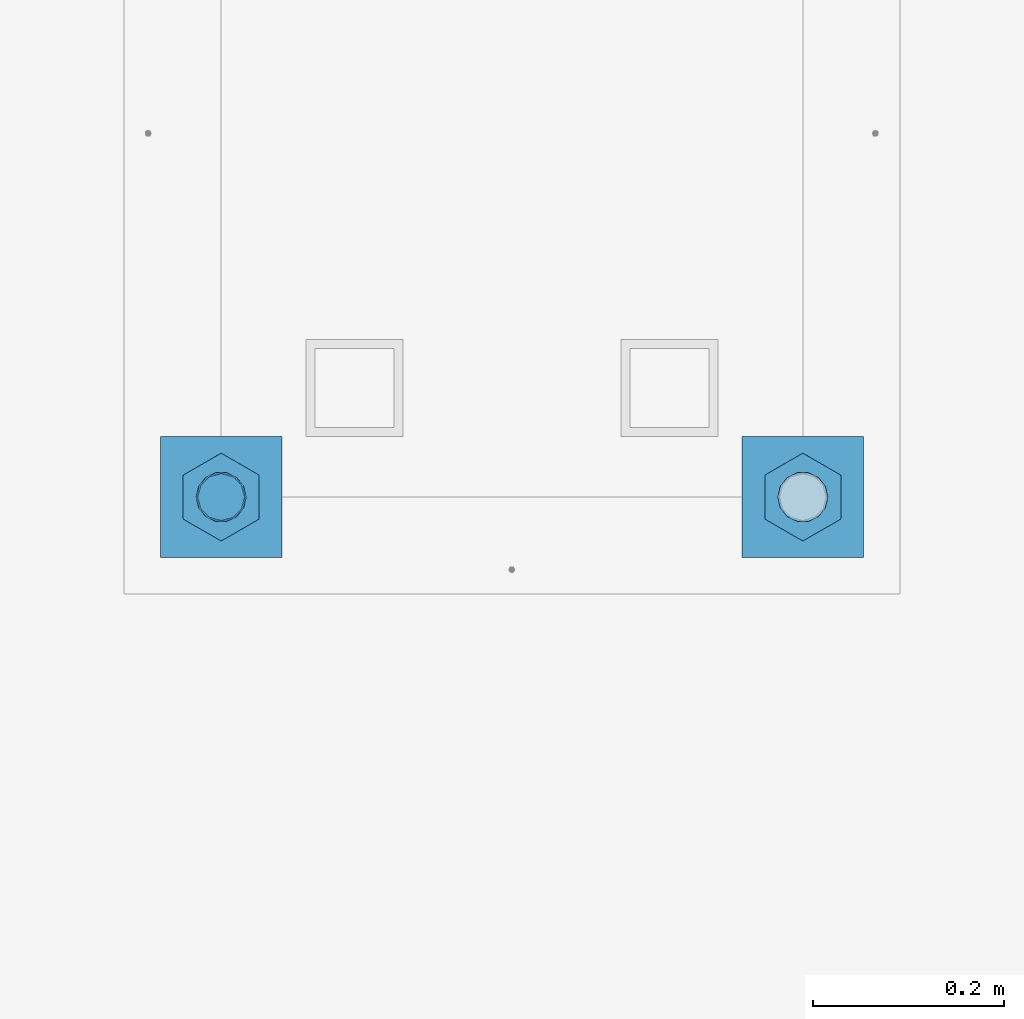
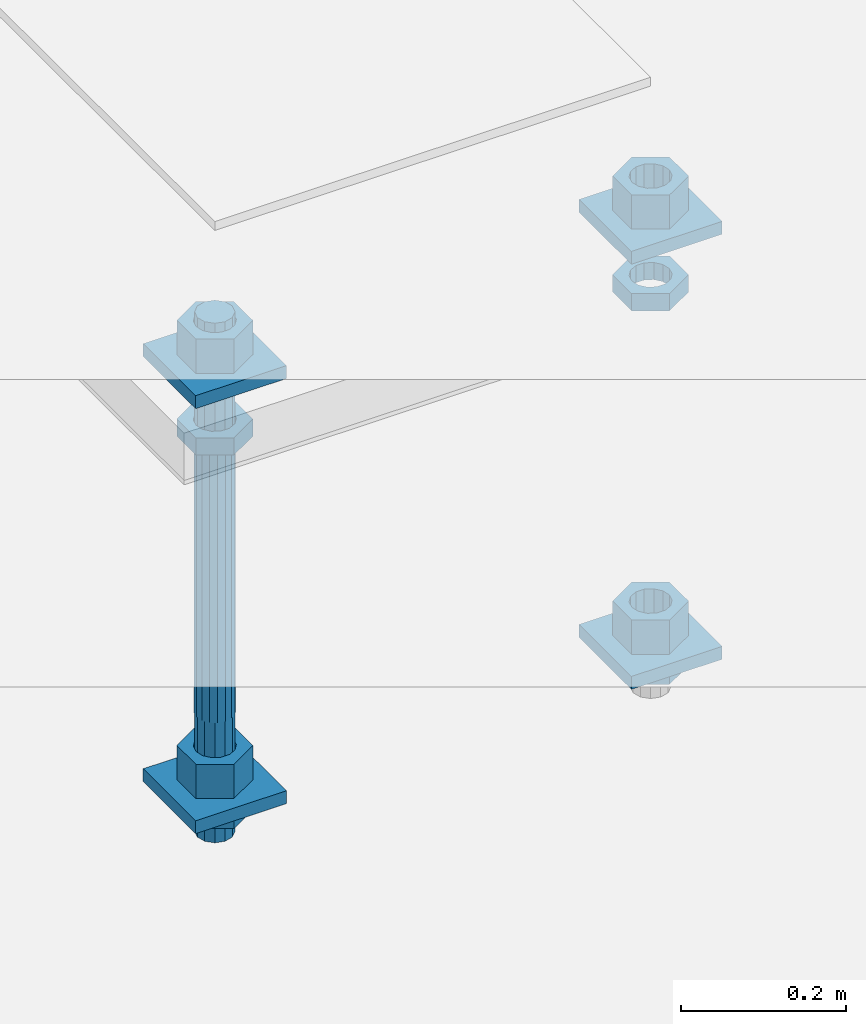
# One storey, part 2721 of 3843: 13 beams, 1 element without a shape of its own.
"""IFC2X3 building model written with IfcOpenShell, lengths in millimetres."""

from ifc_helpers import new_model, si_unit, frame, origin_with_axes, place, context, subcontext, project, spatial, faceted_brep, material, type_object, element, aggregate, save


model = new_model("IFC2X3")

# Units and contexts
model_context = context("Model", 3, precision=1e-05, world=origin_with_axes())
body_context = subcontext(model_context, "Body", "Model", "MODEL_VIEW")
ifc_project = project(units=[si_unit("LENGTHUNIT", "METRE", prefix="MILLI"), si_unit("AREAUNIT", "SQUARE_METRE"), si_unit("VOLUMEUNIT", "CUBIC_METRE"), si_unit("MASSUNIT", "GRAM", prefix="KILO"), si_unit("TIMEUNIT", "SECOND"), si_unit("PLANEANGLEUNIT", "RADIAN"), si_unit("SOLIDANGLEUNIT", "STERADIAN"), si_unit("THERMODYNAMICTEMPERATUREUNIT", "DEGREE_CELSIUS"), si_unit("LUMINOUSINTENSITYUNIT", "LUMEN")], contexts=[model_context])

# Site, building, storey
site_placement = place(None, origin_with_axes())
site = spatial("IfcSite", under=ifc_project, at=site_placement, CompositionType="ELEMENT")
building_placement = place(site_placement, origin_with_axes())
building = spatial("IfcBuilding", under=site, at=building_placement, Name="Undefined", CompositionType="ELEMENT")
storey_placement = place(building_placement, origin_with_axes())
storey = spatial("IfcBuildingStorey", under=building, at=storey_placement, Name="Undefined", CompositionType="ELEMENT", Elevation=0.0)

# Assembly, beams
assembly_placement = place(storey_placement, origin_with_axes())
assembly = element("IfcElementAssembly", 1, at=assembly_placement, inside=storey, Name="TEMPLATE", AssemblyPlace="NOTDEFINED", PredefinedType="RIGID_FRAME")
ifc_material_1 = material(Name="STEEL/A36")
beam_type_1 = type_object("IfcBeamType", PredefinedType="NOTDEFINED")
beam_1_placement = place(assembly_placement, frame((111798.099998474, 32080.2, 29873.575), z_axis=(0.0, 1.0, 0.0), x_axis=(-1.0, 0.0, 0.0)))
beam_1 = element("IfcBeam", 2, at=beam_1_placement, type_object=beam_type_1, material=ifc_material_1, Name="WASHER_PLATE", context=body_context, shape_type="Brep", body=[
    faceted_brep([(0.0, 9.52500000000146, -63.5), (0.0, 9.52500000000146, 63.5), (127.0, 9.52500000000146, 63.5), (127.0, 9.52500000000146, -63.5), (0.0, -9.52500000000146, 63.5), (127.0, -9.52500000000146, 63.5), (0.0, -9.52500000000146, -63.5), (127.0, -9.52500000000146, -63.5)], [[[0, 1, 2, 3]], [[1, 4, 5, 2]], [[4, 6, 7, 5]], [[6, 0, 3, 7]], [[5, 7, 3, 2]], [[6, 4, 1, 0]]]),
])
beam_2_placement = place(assembly_placement, frame((112407.7, 32080.2, 29873.575), z_axis=(0.0, 1.0, 0.0), x_axis=(-1.0, 0.0, 0.0)))
beam_2 = element("IfcBeam", 3, at=beam_2_placement, type_object=beam_type_1, material=ifc_material_1, Name="WASHER_PLATE", context=body_context, shape_type="Brep", body=[
    faceted_brep([(0.0, 9.52500000000146, -63.5), (0.0, 9.52500000000146, 63.5), (127.0, 9.52500000000146, 63.5), (127.0, 9.52500000000146, -63.5), (0.0, -9.52500000000146, 63.5), (127.0, -9.52500000000146, 63.5), (0.0, -9.52500000000146, -63.5), (127.0, -9.52500000000146, -63.5)], [[[0, 1, 2, 3]], [[1, 4, 5, 2]], [[4, 6, 7, 5]], [[6, 0, 3, 7]], [[5, 7, 3, 2]], [[6, 4, 1, 0]]]),
])
beam_3_placement = place(assembly_placement, frame((111798.099998474, 32080.2, 29244.925), z_axis=(0.0, 1.0, 0.0), x_axis=(-1.0, 0.0, 0.0)))
beam_3 = element("IfcBeam", 4, at=beam_3_placement, type_object=beam_type_1, material=ifc_material_1, Name="WASHER_PLATE", context=body_context, shape_type="Brep", body=[
    faceted_brep([(0.0, 9.52500000000146, -63.5), (0.0, 9.52500000000146, 63.5), (127.0, 9.52500000000146, 63.5), (127.0, 9.52500000000146, -63.5), (0.0, -9.52500000000146, 63.5), (127.0, -9.52500000000146, 63.5), (0.0, -9.52500000000146, -63.5), (127.0, -9.52500000000146, -63.5)], [[[0, 1, 2, 3]], [[1, 4, 5, 2]], [[4, 6, 7, 5]], [[6, 0, 3, 7]], [[5, 7, 3, 2]], [[6, 4, 1, 0]]]),
])
beam_4_placement = place(assembly_placement, frame((112407.7, 32080.2, 29244.925), z_axis=(0.0, 1.0, 0.0), x_axis=(-1.0, 0.0, 0.0)))
beam_4 = element("IfcBeam", 5, at=beam_4_placement, type_object=beam_type_1, material=ifc_material_1, Name="WASHER_PLATE", context=body_context, shape_type="Brep", body=[
    faceted_brep([(0.0, 9.52500000000146, -63.5), (0.0, 9.52500000000146, 63.5), (127.0, 9.52500000000146, 63.5), (127.0, 9.52500000000146, -63.5), (0.0, -9.52500000000146, 63.5), (127.0, -9.52500000000146, 63.5), (0.0, -9.52500000000146, -63.5), (127.0, -9.52500000000146, -63.5)], [[[0, 1, 2, 3]], [[1, 4, 5, 2]], [[4, 6, 7, 5]], [[6, 0, 3, 7]], [[5, 7, 3, 2]], [[6, 4, 1, 0]]]),
])
beam_type_2 = type_object("IfcBeamType", Name="2_HALF_NUT", PredefinedType="NOTDEFINED")
beam_5_placement = place(assembly_placement, frame((111734.599998474, 32080.2, 29787.85), z_axis=(-1.0, 0.0, 0.0), x_axis=(0.0, 0.0, -1.0)))
beam_5 = element("IfcBeam", 6, at=beam_5_placement, type_object=beam_type_2, material=ifc_material_1, Name="NUT", ObjectType="2_HALF_NUT", context=body_context, shape_type="Brep", body=[
    faceted_brep([(0.0, -46.0369987487793, 0.0), (0.0, -23.0184993743896, -39.869213104248), (25.4000000000015, -23.0184993743896, -39.869213104248), (25.4000000000015, -46.0369987487793, 0.0), (0.0, 23.0184993743896, -39.869213104248), (25.4000000000015, 23.0184993743896, -39.869213104248), (0.0, 46.0369987487793, 0.0), (25.4000000000015, 46.0369987487793, 0.0), (0.0, 23.0184993743896, 39.869213104248), (25.4000000000015, 23.0184993743896, 39.869213104248), (0.0, -23.0184993743896, 39.869213104248), (25.4000000000015, -23.0184993743896, 39.869213104248), (0.0, 0.0, 26.1940002441406), (0.0, 11.3650617044477, 23.5999013092805), (25.4000000000015, 11.3650617044477, 23.5999013092805), (25.4000000000015, 0.0, 26.1940002441406), (0.0, 20.4791109456419, 16.3316083006721), (25.4000000000015, 20.4791109456419, 16.3316083006721), (0.0, 25.5370200498292, 5.82867859874386), (25.4000000000015, 25.5370200498292, 5.82867859874386), (0.0, 25.5370200498292, -5.82867859874386), (25.4000000000015, 25.5370200498292, -5.82867859874386), (0.0, 20.4791109456419, -16.3316083006721), (25.4000000000015, 20.4791109456419, -16.3316083006721), (0.0, 11.3650617044477, -23.5999013092805), (25.4000000000015, 11.3650617044477, -23.5999013092805), (0.0, 0.0, -26.1940002441406), (25.4000000000015, 0.0, -26.1940002441406), (0.0, -11.3650617044477, -23.5999013092805), (25.4000000000015, -11.3650617044477, -23.5999013092805), (0.0, -20.4791109456419, -16.3316083006721), (25.4000000000015, -20.4791109456419, -16.3316083006721), (0.0, -25.5370200498292, -5.82867859874386), (25.4000000000015, -25.5370200498292, -5.82867859874386), (0.0, -25.5370200498292, 5.82867859874386), (25.4000000000015, -25.5370200498292, 5.82867859874386), (0.0, -20.4791109456419, 16.3316083006721), (25.4000000000015, -20.4791109456419, 16.3316083006721), (0.0, -11.3650617044477, 23.5999013092805), (25.4000000000015, -11.3650617044477, 23.5999013092805)], [[[0, 1, 2, 3]], [[1, 4, 5, 2]], [[4, 6, 7, 5]], [[6, 8, 9, 7]], [[8, 10, 11, 9]], [[10, 0, 3, 11]], [[12, 13, 14, 15]], [[13, 16, 17, 14]], [[16, 18, 19, 17]], [[18, 20, 21, 19]], [[20, 22, 23, 21]], [[22, 24, 25, 23]], [[24, 26, 27, 25]], [[26, 28, 29, 27]], [[28, 30, 31, 29]], [[30, 32, 33, 31]], [[32, 34, 35, 33]], [[34, 36, 37, 35]], [[36, 38, 39, 37]], [[38, 12, 15, 39]], [[5, 7, 9, 11, 3, 2], [17, 19, 21, 23, 25, 27, 29, 31, 33, 35, 37, 39, 15, 14]], [[10, 8, 6, 4, 1, 0], [38, 36, 34, 32, 30, 28, 26, 24, 22, 20, 18, 16, 13, 12]]]),
])
beam_6_placement = place(assembly_placement, frame((111734.599998474, 32080.2, 29235.4), z_axis=(-1.0, 0.0, 0.0), x_axis=(0.0, 0.0, -1.0)))
beam_6 = element("IfcBeam", 7, at=beam_6_placement, type_object=beam_type_2, material=ifc_material_1, Name="NUT", ObjectType="2_HALF_NUT", context=body_context, shape_type="Brep", body=[
    faceted_brep([(0.0, -46.0369987487793, 0.0), (0.0, -23.0184993743896, -39.869213104248), (25.4000000000015, -23.0184993743896, -39.869213104248), (25.4000000000015, -46.0369987487793, 0.0), (0.0, 23.0184993743896, -39.869213104248), (25.4000000000015, 23.0184993743896, -39.869213104248), (0.0, 46.0369987487793, 0.0), (25.4000000000015, 46.0369987487793, 0.0), (0.0, 23.0184993743896, 39.869213104248), (25.4000000000015, 23.0184993743896, 39.869213104248), (0.0, -23.0184993743896, 39.869213104248), (25.4000000000015, -23.0184993743896, 39.869213104248), (0.0, 0.0, 26.1940002441406), (0.0, 11.3650617044477, 23.5999013092805), (25.4000000000015, 11.3650617044477, 23.5999013092805), (25.4000000000015, 0.0, 26.1940002441406), (0.0, 20.4791109456419, 16.3316083006721), (25.4000000000015, 20.4791109456419, 16.3316083006721), (0.0, 25.5370200498292, 5.82867859874386), (25.4000000000015, 25.5370200498292, 5.82867859874386), (0.0, 25.5370200498292, -5.82867859874386), (25.4000000000015, 25.5370200498292, -5.82867859874386), (0.0, 20.4791109456419, -16.3316083006721), (25.4000000000015, 20.4791109456419, -16.3316083006721), (0.0, 11.3650617044477, -23.5999013092805), (25.4000000000015, 11.3650617044477, -23.5999013092805), (0.0, 0.0, -26.1940002441406), (25.4000000000015, 0.0, -26.1940002441406), (0.0, -11.3650617044477, -23.5999013092805), (25.4000000000015, -11.3650617044477, -23.5999013092805), (0.0, -20.4791109456419, -16.3316083006721), (25.4000000000015, -20.4791109456419, -16.3316083006721), (0.0, -25.5370200498292, -5.82867859874386), (25.4000000000015, -25.5370200498292, -5.82867859874386), (0.0, -25.5370200498292, 5.82867859874386), (25.4000000000015, -25.5370200498292, 5.82867859874386), (0.0, -20.4791109456419, 16.3316083006721), (25.4000000000015, -20.4791109456419, 16.3316083006721), (0.0, -11.3650617044477, 23.5999013092805), (25.4000000000015, -11.3650617044477, 23.5999013092805)], [[[0, 1, 2, 3]], [[1, 4, 5, 2]], [[4, 6, 7, 5]], [[6, 8, 9, 7]], [[8, 10, 11, 9]], [[10, 0, 3, 11]], [[12, 13, 14, 15]], [[13, 16, 17, 14]], [[16, 18, 19, 17]], [[18, 20, 21, 19]], [[20, 22, 23, 21]], [[22, 24, 25, 23]], [[24, 26, 27, 25]], [[26, 28, 29, 27]], [[28, 30, 31, 29]], [[30, 32, 33, 31]], [[32, 34, 35, 33]], [[34, 36, 37, 35]], [[36, 38, 39, 37]], [[38, 12, 15, 39]], [[5, 7, 9, 11, 3, 2], [17, 19, 21, 23, 25, 27, 29, 31, 33, 35, 37, 39, 15, 14]], [[10, 8, 6, 4, 1, 0], [38, 36, 34, 32, 30, 28, 26, 24, 22, 20, 18, 16, 13, 12]]]),
])
beam_7_placement = place(assembly_placement, frame((112344.2, 32080.2, 29787.85), z_axis=(-1.0, 0.0, 0.0), x_axis=(0.0, 0.0, -1.0)))
beam_7 = element("IfcBeam", 8, at=beam_7_placement, type_object=beam_type_2, material=ifc_material_1, Name="NUT", ObjectType="2_HALF_NUT", context=body_context, shape_type="Brep", body=[
    faceted_brep([(0.0, -46.0369987487793, 0.0), (0.0, -23.0184993743896, -39.869213104248), (25.4000000000015, -23.0184993743896, -39.869213104248), (25.4000000000015, -46.0369987487793, 0.0), (0.0, 23.0184993743896, -39.869213104248), (25.4000000000015, 23.0184993743896, -39.869213104248), (0.0, 46.0369987487793, 0.0), (25.4000000000015, 46.0369987487793, 0.0), (0.0, 23.0184993743896, 39.869213104248), (25.4000000000015, 23.0184993743896, 39.869213104248), (0.0, -23.0184993743896, 39.869213104248), (25.4000000000015, -23.0184993743896, 39.869213104248), (0.0, 0.0, 26.1940002441406), (0.0, 11.3650617044477, 23.5999013092805), (25.4000000000015, 11.3650617044477, 23.5999013092805), (25.4000000000015, 0.0, 26.1940002441406), (0.0, 20.4791109456419, 16.3316083006721), (25.4000000000015, 20.4791109456419, 16.3316083006721), (0.0, 25.5370200498292, 5.82867859874386), (25.4000000000015, 25.5370200498292, 5.82867859874386), (0.0, 25.5370200498292, -5.82867859874386), (25.4000000000015, 25.5370200498292, -5.82867859874386), (0.0, 20.4791109456419, -16.3316083006721), (25.4000000000015, 20.4791109456419, -16.3316083006721), (0.0, 11.3650617044477, -23.5999013092805), (25.4000000000015, 11.3650617044477, -23.5999013092805), (0.0, 0.0, -26.1940002441406), (25.4000000000015, 0.0, -26.1940002441406), (0.0, -11.3650617044477, -23.5999013092805), (25.4000000000015, -11.3650617044477, -23.5999013092805), (0.0, -20.4791109456419, -16.3316083006721), (25.4000000000015, -20.4791109456419, -16.3316083006721), (0.0, -25.5370200498292, -5.82867859874386), (25.4000000000015, -25.5370200498292, -5.82867859874386), (0.0, -25.5370200498292, 5.82867859874386), (25.4000000000015, -25.5370200498292, 5.82867859874386), (0.0, -20.4791109456419, 16.3316083006721), (25.4000000000015, -20.4791109456419, 16.3316083006721), (0.0, -11.3650617044477, 23.5999013092805), (25.4000000000015, -11.3650617044477, 23.5999013092805)], [[[0, 1, 2, 3]], [[1, 4, 5, 2]], [[4, 6, 7, 5]], [[6, 8, 9, 7]], [[8, 10, 11, 9]], [[10, 0, 3, 11]], [[12, 13, 14, 15]], [[13, 16, 17, 14]], [[16, 18, 19, 17]], [[18, 20, 21, 19]], [[20, 22, 23, 21]], [[22, 24, 25, 23]], [[24, 26, 27, 25]], [[26, 28, 29, 27]], [[28, 30, 31, 29]], [[30, 32, 33, 31]], [[32, 34, 35, 33]], [[34, 36, 37, 35]], [[36, 38, 39, 37]], [[38, 12, 15, 39]], [[5, 7, 9, 11, 3, 2], [17, 19, 21, 23, 25, 27, 29, 31, 33, 35, 37, 39, 15, 14]], [[10, 8, 6, 4, 1, 0], [38, 36, 34, 32, 30, 28, 26, 24, 22, 20, 18, 16, 13, 12]]]),
])
beam_8_placement = place(assembly_placement, frame((112344.2, 32080.2, 29235.4), z_axis=(-1.0, 0.0, 0.0), x_axis=(0.0, 0.0, -1.0)))
beam_8 = element("IfcBeam", 9, at=beam_8_placement, type_object=beam_type_2, material=ifc_material_1, Name="NUT", ObjectType="2_HALF_NUT", context=body_context, shape_type="Brep", body=[
    faceted_brep([(0.0, -46.0369987487793, 0.0), (0.0, -23.0184993743896, -39.869213104248), (25.4000000000015, -23.0184993743896, -39.869213104248), (25.4000000000015, -46.0369987487793, 0.0), (0.0, 23.0184993743896, -39.869213104248), (25.4000000000015, 23.0184993743896, -39.869213104248), (0.0, 46.0369987487793, 0.0), (25.4000000000015, 46.0369987487793, 0.0), (0.0, 23.0184993743896, 39.869213104248), (25.4000000000015, 23.0184993743896, 39.869213104248), (0.0, -23.0184993743896, 39.869213104248), (25.4000000000015, -23.0184993743896, 39.869213104248), (0.0, 0.0, 26.1940002441406), (0.0, 11.3650617044477, 23.5999013092805), (25.4000000000015, 11.3650617044477, 23.5999013092805), (25.4000000000015, 0.0, 26.1940002441406), (0.0, 20.4791109456419, 16.3316083006721), (25.4000000000015, 20.4791109456419, 16.3316083006721), (0.0, 25.5370200498292, 5.82867859874386), (25.4000000000015, 25.5370200498292, 5.82867859874386), (0.0, 25.5370200498292, -5.82867859874386), (25.4000000000015, 25.5370200498292, -5.82867859874386), (0.0, 20.4791109456419, -16.3316083006721), (25.4000000000015, 20.4791109456419, -16.3316083006721), (0.0, 11.3650617044477, -23.5999013092805), (25.4000000000015, 11.3650617044477, -23.5999013092805), (0.0, 0.0, -26.1940002441406), (25.4000000000015, 0.0, -26.1940002441406), (0.0, -11.3650617044477, -23.5999013092805), (25.4000000000015, -11.3650617044477, -23.5999013092805), (0.0, -20.4791109456419, -16.3316083006721), (25.4000000000015, -20.4791109456419, -16.3316083006721), (0.0, -25.5370200498292, -5.82867859874386), (25.4000000000015, -25.5370200498292, -5.82867859874386), (0.0, -25.5370200498292, 5.82867859874386), (25.4000000000015, -25.5370200498292, 5.82867859874386), (0.0, -20.4791109456419, 16.3316083006721), (25.4000000000015, -20.4791109456419, 16.3316083006721), (0.0, -11.3650617044477, 23.5999013092805), (25.4000000000015, -11.3650617044477, 23.5999013092805)], [[[0, 1, 2, 3]], [[1, 4, 5, 2]], [[4, 6, 7, 5]], [[6, 8, 9, 7]], [[8, 10, 11, 9]], [[10, 0, 3, 11]], [[12, 13, 14, 15]], [[13, 16, 17, 14]], [[16, 18, 19, 17]], [[18, 20, 21, 19]], [[20, 22, 23, 21]], [[22, 24, 25, 23]], [[24, 26, 27, 25]], [[26, 28, 29, 27]], [[28, 30, 31, 29]], [[30, 32, 33, 31]], [[32, 34, 35, 33]], [[34, 36, 37, 35]], [[36, 38, 39, 37]], [[38, 12, 15, 39]], [[5, 7, 9, 11, 3, 2], [17, 19, 21, 23, 25, 27, 29, 31, 33, 35, 37, 39, 15, 14]], [[10, 8, 6, 4, 1, 0], [38, 36, 34, 32, 30, 28, 26, 24, 22, 20, 18, 16, 13, 12]]]),
])
beam_type_3 = type_object("IfcBeamType", Name="2_HEAVY_HEX_NUT", PredefinedType="NOTDEFINED")
beam_9_placement = place(assembly_placement, frame((111734.599998474, 32080.2, 29933.9), z_axis=(-1.0, 0.0, 0.0), x_axis=(0.0, 0.0, -1.0)))
beam_9 = element("IfcBeam", 10, at=beam_9_placement, type_object=beam_type_3, material=ifc_material_1, Name="NUT", ObjectType="2_HEAVY_HEX_NUT", context=body_context, shape_type="Brep", body=[
    faceted_brep([(0.0, -46.0369987487793, 0.0), (0.0, -23.0184993743896, -39.869213104248), (50.7999999999993, -23.0184993743896, -39.869213104248), (50.7999999999993, -46.0369987487793, 0.0), (0.0, 23.0184993743896, -39.869213104248), (50.7999999999993, 23.0184993743896, -39.869213104248), (0.0, 46.0369987487793, 0.0), (50.7999999999993, 46.0369987487793, 0.0), (0.0, 23.0184993743896, 39.869213104248), (50.7999999999993, 23.0184993743896, 39.869213104248), (0.0, -23.0184993743896, 39.869213104248), (50.7999999999993, -23.0184993743896, 39.869213104248), (0.0, 0.0, 26.1940002441406), (0.0, 11.3650617044477, 23.5999013092805), (50.7999999999993, 11.3650617044477, 23.5999013092805), (50.7999999999993, 0.0, 26.1940002441406), (0.0, 20.4791109456419, 16.3316083006721), (50.7999999999993, 20.4791109456419, 16.3316083006721), (0.0, 25.5370200498292, 5.82867859874386), (50.7999999999993, 25.5370200498292, 5.82867859874386), (0.0, 25.5370200498292, -5.82867859874386), (50.7999999999993, 25.5370200498292, -5.82867859874386), (0.0, 20.4791109456419, -16.3316083006721), (50.7999999999993, 20.4791109456419, -16.3316083006721), (0.0, 11.3650617044477, -23.5999013092805), (50.7999999999993, 11.3650617044477, -23.5999013092805), (0.0, 0.0, -26.1940002441406), (50.7999999999993, 0.0, -26.1940002441406), (0.0, -11.3650617044477, -23.5999013092805), (50.7999999999993, -11.3650617044477, -23.5999013092805), (0.0, -20.4791109456419, -16.3316083006721), (50.7999999999993, -20.4791109456419, -16.3316083006721), (0.0, -25.5370200498292, -5.82867859874386), (50.7999999999993, -25.5370200498292, -5.82867859874386), (0.0, -25.5370200498292, 5.82867859874386), (50.7999999999993, -25.5370200498292, 5.82867859874386), (0.0, -20.4791109456419, 16.3316083006721), (50.7999999999993, -20.4791109456419, 16.3316083006721), (0.0, -11.3650617044477, 23.5999013092805), (50.7999999999993, -11.3650617044477, 23.5999013092805)], [[[0, 1, 2, 3]], [[1, 4, 5, 2]], [[4, 6, 7, 5]], [[6, 8, 9, 7]], [[8, 10, 11, 9]], [[10, 0, 3, 11]], [[12, 13, 14, 15]], [[13, 16, 17, 14]], [[16, 18, 19, 17]], [[18, 20, 21, 19]], [[20, 22, 23, 21]], [[22, 24, 25, 23]], [[24, 26, 27, 25]], [[26, 28, 29, 27]], [[28, 30, 31, 29]], [[30, 32, 33, 31]], [[32, 34, 35, 33]], [[34, 36, 37, 35]], [[36, 38, 39, 37]], [[38, 12, 15, 39]], [[5, 7, 9, 11, 3, 2], [17, 19, 21, 23, 25, 27, 29, 31, 33, 35, 37, 39, 15, 14]], [[10, 8, 6, 4, 1, 0], [38, 36, 34, 32, 30, 28, 26, 24, 22, 20, 18, 16, 13, 12]]]),
])
beam_10_placement = place(assembly_placement, frame((111734.599998474, 32080.2, 29305.25), z_axis=(-1.0, 0.0, 0.0), x_axis=(0.0, 0.0, -1.0)))
beam_10 = element("IfcBeam", 11, at=beam_10_placement, type_object=beam_type_3, material=ifc_material_1, Name="NUT", ObjectType="2_HEAVY_HEX_NUT", context=body_context, shape_type="Brep", body=[
    faceted_brep([(0.0, -46.0369987487793, 0.0), (0.0, -23.0184993743896, -39.869213104248), (50.7999999999993, -23.0184993743896, -39.869213104248), (50.7999999999993, -46.0369987487793, 0.0), (0.0, 23.0184993743896, -39.869213104248), (50.7999999999993, 23.0184993743896, -39.869213104248), (0.0, 46.0369987487793, 0.0), (50.7999999999993, 46.0369987487793, 0.0), (0.0, 23.0184993743896, 39.869213104248), (50.7999999999993, 23.0184993743896, 39.869213104248), (0.0, -23.0184993743896, 39.869213104248), (50.7999999999993, -23.0184993743896, 39.869213104248), (0.0, 0.0, 26.1940002441406), (0.0, 11.3650617044477, 23.5999013092805), (50.7999999999993, 11.3650617044477, 23.5999013092805), (50.7999999999993, 0.0, 26.1940002441406), (0.0, 20.4791109456419, 16.3316083006721), (50.7999999999993, 20.4791109456419, 16.3316083006721), (0.0, 25.5370200498292, 5.82867859874386), (50.7999999999993, 25.5370200498292, 5.82867859874386), (0.0, 25.5370200498292, -5.82867859874386), (50.7999999999993, 25.5370200498292, -5.82867859874386), (0.0, 20.4791109456419, -16.3316083006721), (50.7999999999993, 20.4791109456419, -16.3316083006721), (0.0, 11.3650617044477, -23.5999013092805), (50.7999999999993, 11.3650617044477, -23.5999013092805), (0.0, 0.0, -26.1940002441406), (50.7999999999993, 0.0, -26.1940002441406), (0.0, -11.3650617044477, -23.5999013092805), (50.7999999999993, -11.3650617044477, -23.5999013092805), (0.0, -20.4791109456419, -16.3316083006721), (50.7999999999993, -20.4791109456419, -16.3316083006721), (0.0, -25.5370200498292, -5.82867859874386), (50.7999999999993, -25.5370200498292, -5.82867859874386), (0.0, -25.5370200498292, 5.82867859874386), (50.7999999999993, -25.5370200498292, 5.82867859874386), (0.0, -20.4791109456419, 16.3316083006721), (50.7999999999993, -20.4791109456419, 16.3316083006721), (0.0, -11.3650617044477, 23.5999013092805), (50.7999999999993, -11.3650617044477, 23.5999013092805)], [[[0, 1, 2, 3]], [[1, 4, 5, 2]], [[4, 6, 7, 5]], [[6, 8, 9, 7]], [[8, 10, 11, 9]], [[10, 0, 3, 11]], [[12, 13, 14, 15]], [[13, 16, 17, 14]], [[16, 18, 19, 17]], [[18, 20, 21, 19]], [[20, 22, 23, 21]], [[22, 24, 25, 23]], [[24, 26, 27, 25]], [[26, 28, 29, 27]], [[28, 30, 31, 29]], [[30, 32, 33, 31]], [[32, 34, 35, 33]], [[34, 36, 37, 35]], [[36, 38, 39, 37]], [[38, 12, 15, 39]], [[5, 7, 9, 11, 3, 2], [17, 19, 21, 23, 25, 27, 29, 31, 33, 35, 37, 39, 15, 14]], [[10, 8, 6, 4, 1, 0], [38, 36, 34, 32, 30, 28, 26, 24, 22, 20, 18, 16, 13, 12]]]),
])
beam_11_placement = place(assembly_placement, frame((112344.2, 32080.2, 29933.9), z_axis=(-1.0, 0.0, 0.0), x_axis=(0.0, 0.0, -1.0)))
beam_11 = element("IfcBeam", 12, at=beam_11_placement, type_object=beam_type_3, material=ifc_material_1, Name="NUT", ObjectType="2_HEAVY_HEX_NUT", context=body_context, shape_type="Brep", body=[
    faceted_brep([(0.0, -46.0369987487793, 0.0), (0.0, -23.0184993743896, -39.869213104248), (50.7999999999993, -23.0184993743896, -39.869213104248), (50.7999999999993, -46.0369987487793, 0.0), (0.0, 23.0184993743896, -39.869213104248), (50.7999999999993, 23.0184993743896, -39.869213104248), (0.0, 46.0369987487793, 0.0), (50.7999999999993, 46.0369987487793, 0.0), (0.0, 23.0184993743896, 39.869213104248), (50.7999999999993, 23.0184993743896, 39.869213104248), (0.0, -23.0184993743896, 39.869213104248), (50.7999999999993, -23.0184993743896, 39.869213104248), (0.0, 0.0, 26.1940002441406), (0.0, 11.3650617044477, 23.5999013092805), (50.7999999999993, 11.3650617044477, 23.5999013092805), (50.7999999999993, 0.0, 26.1940002441406), (0.0, 20.4791109456419, 16.3316083006721), (50.7999999999993, 20.4791109456419, 16.3316083006721), (0.0, 25.5370200498292, 5.82867859874386), (50.7999999999993, 25.5370200498292, 5.82867859874386), (0.0, 25.5370200498292, -5.82867859874386), (50.7999999999993, 25.5370200498292, -5.82867859874386), (0.0, 20.4791109456419, -16.3316083006721), (50.7999999999993, 20.4791109456419, -16.3316083006721), (0.0, 11.3650617044477, -23.5999013092805), (50.7999999999993, 11.3650617044477, -23.5999013092805), (0.0, 0.0, -26.1940002441406), (50.7999999999993, 0.0, -26.1940002441406), (0.0, -11.3650617044477, -23.5999013092805), (50.7999999999993, -11.3650617044477, -23.5999013092805), (0.0, -20.4791109456419, -16.3316083006721), (50.7999999999993, -20.4791109456419, -16.3316083006721), (0.0, -25.5370200498292, -5.82867859874386), (50.7999999999993, -25.5370200498292, -5.82867859874386), (0.0, -25.5370200498292, 5.82867859874386), (50.7999999999993, -25.5370200498292, 5.82867859874386), (0.0, -20.4791109456419, 16.3316083006721), (50.7999999999993, -20.4791109456419, 16.3316083006721), (0.0, -11.3650617044477, 23.5999013092805), (50.7999999999993, -11.3650617044477, 23.5999013092805)], [[[0, 1, 2, 3]], [[1, 4, 5, 2]], [[4, 6, 7, 5]], [[6, 8, 9, 7]], [[8, 10, 11, 9]], [[10, 0, 3, 11]], [[12, 13, 14, 15]], [[13, 16, 17, 14]], [[16, 18, 19, 17]], [[18, 20, 21, 19]], [[20, 22, 23, 21]], [[22, 24, 25, 23]], [[24, 26, 27, 25]], [[26, 28, 29, 27]], [[28, 30, 31, 29]], [[30, 32, 33, 31]], [[32, 34, 35, 33]], [[34, 36, 37, 35]], [[36, 38, 39, 37]], [[38, 12, 15, 39]], [[5, 7, 9, 11, 3, 2], [17, 19, 21, 23, 25, 27, 29, 31, 33, 35, 37, 39, 15, 14]], [[10, 8, 6, 4, 1, 0], [38, 36, 34, 32, 30, 28, 26, 24, 22, 20, 18, 16, 13, 12]]]),
])
beam_12_placement = place(assembly_placement, frame((112344.2, 32080.2, 29305.25), z_axis=(-1.0, 0.0, 0.0), x_axis=(0.0, 0.0, -1.0)))
beam_12 = element("IfcBeam", 13, at=beam_12_placement, type_object=beam_type_3, material=ifc_material_1, Name="NUT", ObjectType="2_HEAVY_HEX_NUT", context=body_context, shape_type="Brep", body=[
    faceted_brep([(0.0, -46.0369987487793, 0.0), (0.0, -23.0184993743896, -39.869213104248), (50.7999999999993, -23.0184993743896, -39.869213104248), (50.7999999999993, -46.0369987487793, 0.0), (0.0, 23.0184993743896, -39.869213104248), (50.7999999999993, 23.0184993743896, -39.869213104248), (0.0, 46.0369987487793, 0.0), (50.7999999999993, 46.0369987487793, 0.0), (0.0, 23.0184993743896, 39.869213104248), (50.7999999999993, 23.0184993743896, 39.869213104248), (0.0, -23.0184993743896, 39.869213104248), (50.7999999999993, -23.0184993743896, 39.869213104248), (0.0, 0.0, 26.1940002441406), (0.0, 11.3650617044477, 23.5999013092805), (50.7999999999993, 11.3650617044477, 23.5999013092805), (50.7999999999993, 0.0, 26.1940002441406), (0.0, 20.4791109456419, 16.3316083006721), (50.7999999999993, 20.4791109456419, 16.3316083006721), (0.0, 25.5370200498292, 5.82867859874386), (50.7999999999993, 25.5370200498292, 5.82867859874386), (0.0, 25.5370200498292, -5.82867859874386), (50.7999999999993, 25.5370200498292, -5.82867859874386), (0.0, 20.4791109456419, -16.3316083006721), (50.7999999999993, 20.4791109456419, -16.3316083006721), (0.0, 11.3650617044477, -23.5999013092805), (50.7999999999993, 11.3650617044477, -23.5999013092805), (0.0, 0.0, -26.1940002441406), (50.7999999999993, 0.0, -26.1940002441406), (0.0, -11.3650617044477, -23.5999013092805), (50.7999999999993, -11.3650617044477, -23.5999013092805), (0.0, -20.4791109456419, -16.3316083006721), (50.7999999999993, -20.4791109456419, -16.3316083006721), (0.0, -25.5370200498292, -5.82867859874386), (50.7999999999993, -25.5370200498292, -5.82867859874386), (0.0, -25.5370200498292, 5.82867859874386), (50.7999999999993, -25.5370200498292, 5.82867859874386), (0.0, -20.4791109456419, 16.3316083006721), (50.7999999999993, -20.4791109456419, 16.3316083006721), (0.0, -11.3650617044477, 23.5999013092805), (50.7999999999993, -11.3650617044477, 23.5999013092805)], [[[0, 1, 2, 3]], [[1, 4, 5, 2]], [[4, 6, 7, 5]], [[6, 8, 9, 7]], [[8, 10, 11, 9]], [[10, 0, 3, 11]], [[12, 13, 14, 15]], [[13, 16, 17, 14]], [[16, 18, 19, 17]], [[18, 20, 21, 19]], [[20, 22, 23, 21]], [[22, 24, 25, 23]], [[24, 26, 27, 25]], [[26, 28, 29, 27]], [[28, 30, 31, 29]], [[30, 32, 33, 31]], [[32, 34, 35, 33]], [[34, 36, 37, 35]], [[36, 38, 39, 37]], [[38, 12, 15, 39]], [[5, 7, 9, 11, 3, 2], [17, 19, 21, 23, 25, 27, 29, 31, 33, 35, 37, 39, 15, 14]], [[10, 8, 6, 4, 1, 0], [38, 36, 34, 32, 30, 28, 26, 24, 22, 20, 18, 16, 13, 12]]]),
])
ifc_material_2 = material()
beam_type_4 = type_object("IfcBeamType", PredefinedType="NOTDEFINED")
beam_13_placement = place(assembly_placement, frame((111734.599998474, 32080.2, 29762.45), z_axis=(-1.0, 0.0, 0.0), x_axis=(0.0, 0.0, -1.0)))
beam_13 = element("IfcBeam", 14, at=beam_13_placement, type_object=beam_type_4, material=ifc_material_2, Name="ANCHOR_ROD", context=body_context, shape_type="Brep", body=[
    faceted_brep([(-184.150000000001, -21.217622392709, 12.25), (-184.150000000001, -12.2499999999854, 21.2176223927163), (-184.150000000001, 1.45519152283669e-11, 24.5), (-184.150000000001, 12.2500000000146, 21.2176223927163), (-184.150000000001, 21.2176223927381, 12.25), (-184.150000000001, 24.5000000000146, 0.0), (-184.150000000001, 21.2176223927381, -12.25), (-184.150000000001, 12.2500000000146, -21.2176223927163), (-184.150000000001, 1.45519152283669e-11, -24.5), (-184.150000000001, -12.2499999999854, -21.2176223927163), (-184.150000000001, -21.217622392709, -12.25), (-184.150000000001, -24.4999999999854, 0.0), (0.0, 24.5000000000146, 0.0), (0.0, 21.2176223927381, -12.25), (0.0, 12.2500000000146, -21.2176223927163), (0.0, 1.45519152283669e-11, -24.5), (0.0, -12.2499999999854, -21.2176223927163), (0.0, -21.217622392709, -12.25), (0.0, -24.4999999999854, 0.0), (0.0, -21.217622392709, 12.25), (0.0, -12.2499999999854, 21.2176223927163), (0.0, 1.45519152283669e-11, 24.5), (0.0, 12.2500000000146, 21.2176223927163), (0.0, 21.2176223927381, 12.25), (0.0, -23.4665401257807, 9.72015918207035), (0.0, -17.9605122421344, 17.9605122421417), (0.0, -9.72015918207762, 23.466540125788), (0.0, 0.0, 25.4000000000015), (0.0, 9.72015918207762, 23.466540125788), (0.0, 17.9605122421344, 17.9605122421417), (0.0, 23.4665401257807, 9.72015918207035), (0.0, 25.3999996185303, 0.0), (0.0, 23.4665401257807, -9.72015918207035), (0.0, 17.9605122421344, -17.9605122421417), (0.0, 9.72015918207762, -23.466540125788), (0.0, 0.0, -25.4000000000015), (0.0, -9.72015918207762, -23.466540125788), (0.0, -17.9605122421344, -17.9605122421417), (0.0, -23.4665401257807, -9.72015918207035), (0.0, -25.3999996185303, 0.0), (406.399999999998, -25.3999999999942, 0.0), (406.399999999998, -23.4665401257807, 9.72015918207035), (406.399999999998, -17.9605122421344, 17.9605122421417), (406.399999999998, -9.72015918207762, 23.466540125788), (406.399999999998, 0.0, 25.4000000000015), (406.399999999998, 9.72015918207762, 23.466540125788), (406.399999999998, 17.9605122421344, 17.9605122421417), (406.399999999998, 23.4665401257807, 9.72015918207035), (406.399999999998, 25.3999999999942, 0.0), (406.399999999998, 23.4665401257807, -9.72015918207035), (406.399999999998, 17.9605122421344, -17.9605122421417), (406.399999999998, 9.72015918207762, -23.466540125788), (406.399999999998, 0.0, -25.4000000000015), (406.399999999998, -9.72015918207762, -23.466540125788), (406.399999999998, -17.9605122421344, -17.9605122421417), (406.399999999998, -23.4665401257807, -9.72015918207035), (406.399999999998, -12.2499999999854, 21.2176223927163), (406.399999999998, 1.45519152283669e-11, 24.5), (406.399999999998, 12.2500000000146, 21.2176223927163), (406.399999999998, 21.2176223927381, 12.25), (406.399999999998, 24.5000000000146, 0.0), (406.399999999998, 21.2176223927381, -12.25), (406.399999999998, 12.2500000000146, -21.2176223927163), (406.399999999998, 1.45519152283669e-11, -24.5), (406.399999999998, -12.2499999999854, -21.2176223927163), (406.399999999998, -21.217622392709, -12.25), (406.399999999998, -24.4999999999854, 0.0), (406.399999999998, -21.217622392709, 12.25), (584.200000000001, -12.2499999999854, -21.2176223927163), (584.200000000001, 1.45519152283669e-11, -24.5), (584.200000000001, 12.2500000000146, -21.2176223927163), (584.200000000001, 21.2176223927381, -12.25), (584.200000000001, 24.5000000000146, 0.0), (584.200000000001, 21.2176223927381, 12.25), (584.200000000001, 12.2500000000146, 21.2176223927163), (584.200000000001, 1.45519152283669e-11, 24.5), (584.200000000001, -12.2499999999854, 21.2176223927163), (584.200000000001, -21.217622392709, 12.25), (584.200000000001, -24.4999999999854, 0.0), (584.200000000001, -21.217622392709, -12.25)], [[[0, 1, 2, 3, 4, 5, 6, 7, 8, 9, 10, 11]], [[6, 5, 12, 13]], [[7, 6, 13, 14]], [[8, 7, 14, 15]], [[9, 8, 15, 16]], [[10, 9, 16, 17]], [[11, 10, 17, 18]], [[0, 11, 18, 19]], [[1, 0, 19, 20]], [[2, 1, 20, 21]], [[3, 2, 21, 22]], [[4, 3, 22, 23]], [[5, 4, 23, 12]], [[24, 25, 26, 27, 28, 29, 30, 31, 32, 33, 34, 35, 36, 37, 38, 39], [22, 21, 20, 19, 18, 17, 16, 15, 14, 13, 12, 23]], [[24, 39, 40, 41]], [[25, 24, 41, 42]], [[26, 25, 42, 43]], [[27, 26, 43, 44]], [[28, 27, 44, 45]], [[29, 28, 45, 46]], [[30, 29, 46, 47]], [[31, 30, 47, 48]], [[32, 31, 48, 49]], [[33, 32, 49, 50]], [[34, 33, 50, 51]], [[35, 34, 51, 52]], [[36, 35, 52, 53]], [[37, 36, 53, 54]], [[38, 37, 54, 55]], [[39, 38, 55, 40]], [[54, 53, 52, 51, 50, 49, 48, 47, 46, 45, 44, 43, 42, 41, 40, 55], [56, 57, 58, 59, 60, 61, 62, 63, 64, 65, 66, 67]], [[68, 69, 70, 71, 72, 73, 74, 75, 76, 77, 78, 79]], [[76, 75, 57, 56]], [[77, 76, 56, 67]], [[78, 77, 67, 66]], [[79, 78, 66, 65]], [[68, 79, 65, 64]], [[69, 68, 64, 63]], [[70, 69, 63, 62]], [[71, 70, 62, 61]], [[72, 71, 61, 60]], [[73, 72, 60, 59]], [[74, 73, 59, 58]], [[75, 74, 58, 57]]]),
])
aggregate(assembly, [beam_1, beam_2, beam_3, beam_5, beam_9, beam_10, beam_6, beam_13, beam_4, beam_7, beam_11, beam_12, beam_8])

save(model, "model.ifc")
